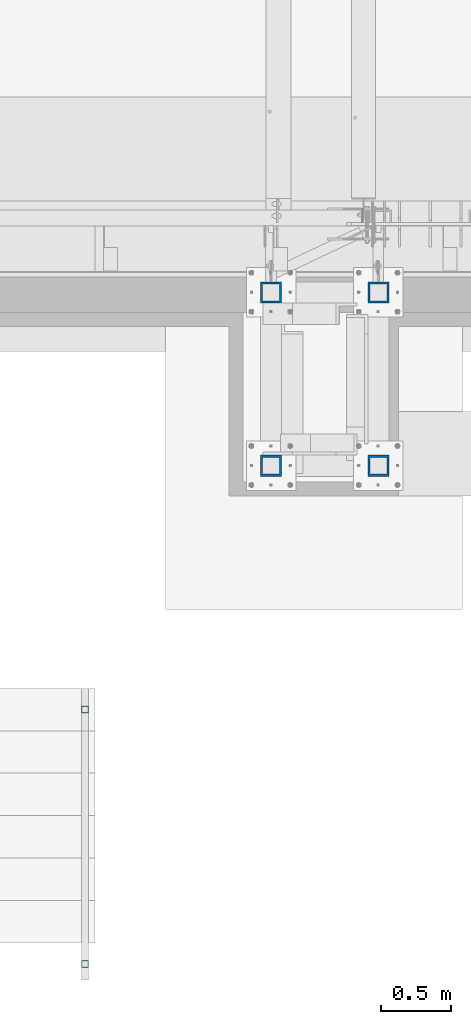
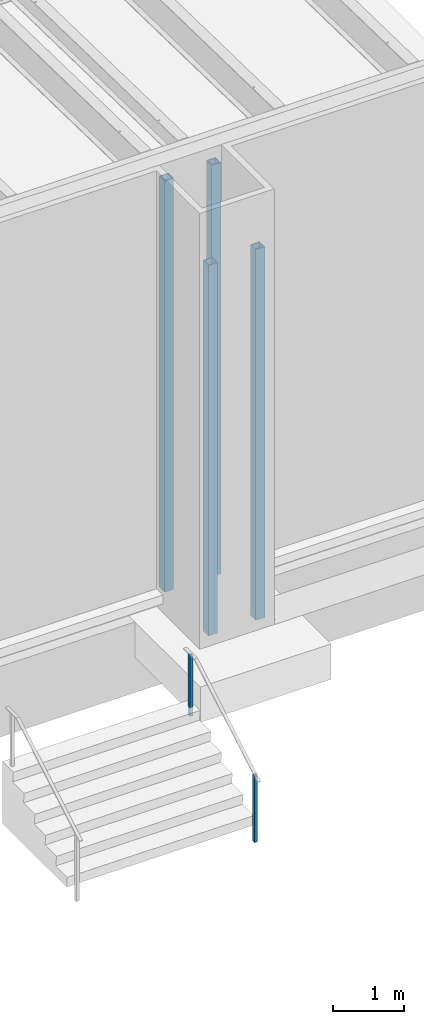
# One storey, part 910 of 1763: 6 columns, 2 elements without a shape of their own.
"""IFC2X3 building model written with IfcOpenShell, lengths in millimetres."""

from ifc_helpers import new_model, si_unit, frame, origin_with_axes, place, context, subcontext, project, spatial, faceted_brep, material, type_object, element, aggregate, save


model = new_model("IFC2X3")

# Units and contexts
model_context = context("Model", 3, precision=1e-05, world=origin_with_axes())
body_context = subcontext(model_context, "Body", "Model", "MODEL_VIEW")
ifc_project = project(units=[si_unit("LENGTHUNIT", "METRE", prefix="MILLI"), si_unit("AREAUNIT", "SQUARE_METRE"), si_unit("VOLUMEUNIT", "CUBIC_METRE"), si_unit("MASSUNIT", "GRAM", prefix="KILO"), si_unit("TIMEUNIT", "SECOND"), si_unit("PLANEANGLEUNIT", "RADIAN"), si_unit("SOLIDANGLEUNIT", "STERADIAN"), si_unit("THERMODYNAMICTEMPERATUREUNIT", "DEGREE_CELSIUS"), si_unit("LUMINOUSINTENSITYUNIT", "LUMEN")], contexts=[model_context])

# Site, building, storey
site_placement = place(None, origin_with_axes())
site = spatial("IfcSite", under=ifc_project, at=site_placement, CompositionType="ELEMENT")
building_placement = place(site_placement, origin_with_axes())
building = spatial("IfcBuilding", under=site, at=building_placement, Name="Undefined", CompositionType="ELEMENT")
storey_placement = place(building_placement, origin_with_axes())
storey = spatial("IfcBuildingStorey", under=building, at=storey_placement, Name="Undefined", CompositionType="ELEMENT", Elevation=0.0)

# Assembly, columns
assembly_1_placement = place(storey_placement, origin_with_axes())
assembly_1 = element("IfcElementAssembly", 1, at=assembly_1_placement, inside=storey, Name="FRAME", AssemblyPlace="NOTDEFINED", PredefinedType="RIGID_FRAME")
ifc_material = material()
column_type_1 = type_object("IfcColumnType", Name="HSS6X6X5/8", PredefinedType="NOTDEFINED")
column_1_placement = place(assembly_1_placement, frame((-29863.4870783858, -14208.1242675181, 5029.2), z_axis=(0.0, 1.0, 0.0), x_axis=(0.0, 0.0, 1.0)))
column_1 = element("IfcColumn", 2, at=column_1_placement, type_object=column_type_1, material=ifc_material, Name="COLUMN", ObjectType="HSS6X6X5/8", context=body_context, shape_type="Brep", body=[
    faceted_brep([(63.4999999999973, 60.3249999999971, -60.3250000000007), (63.4999999999973, -60.3249999999971, -60.3250000000007), (7156.45, -60.3249999999971, -60.3250000000007), (7156.45, 60.3249999999971, -60.3250000000007), (63.4999999999973, -60.3249999999971, 60.3250000000007), (7156.45, -60.3249999999971, 60.3250000000007), (63.4999999999973, 60.3249999999971, 60.3250000000007), (7156.45, 60.3249999999971, 60.3250000000007), (63.4999999999973, 76.1999999999971, -76.2000000000007), (63.4999999999973, 76.1999999999971, 76.2000000000007), (7156.45, 76.1999999999971, 76.2000000000007), (7156.45, 76.1999999999971, -76.2000000000007), (63.4999999999973, -76.1999999999971, 76.2000000000007), (7156.45, -76.1999999999971, 76.2000000000007), (63.4999999999973, -76.1999999999971, -76.2000000000007), (7156.45, -76.1999999999971, -76.2000000000007)], [[[0, 1, 2, 3]], [[1, 4, 5, 2]], [[4, 6, 7, 5]], [[6, 0, 3, 7]], [[8, 9, 10, 11]], [[9, 12, 13, 10]], [[12, 14, 15, 13]], [[14, 8, 11, 15]], [[13, 15, 11, 10], [5, 7, 3, 2]], [[14, 12, 9, 8], [6, 4, 1, 0]]]),
])
column_2_placement = place(assembly_1_placement, frame((-30635.0122736984, -14208.1242675181, 5029.2), z_axis=(0.0, 1.0, 0.0), x_axis=(0.0, 0.0, 1.0)))
column_2 = element("IfcColumn", 3, at=column_2_placement, type_object=column_type_1, material=ifc_material, Name="COLUMN", ObjectType="HSS6X6X5/8", context=body_context, shape_type="Brep", body=[
    faceted_brep([(63.4999999999973, 60.3249999999971, -60.3250000000007), (63.4999999999973, -60.3249999999971, -60.3250000000007), (7156.45, -60.3249999999971, -60.3250000000007), (7156.45, 60.3249999999971, -60.3250000000007), (63.4999999999973, -60.3249999999971, 60.3250000000007), (7156.45, -60.3249999999971, 60.3250000000007), (63.4999999999973, 60.3249999999971, 60.3250000000007), (7156.45, 60.3249999999971, 60.3250000000007), (63.4999999999973, 76.1999999999971, -76.2000000000007), (63.4999999999973, 76.1999999999971, 76.2000000000007), (7156.45, 76.1999999999971, 76.2000000000007), (7156.45, 76.1999999999971, -76.2000000000007), (63.4999999999973, -76.1999999999971, 76.2000000000007), (7156.45, -76.1999999999971, 76.2000000000007), (63.4999999999973, -76.1999999999971, -76.2000000000007), (7156.45, -76.1999999999971, -76.2000000000007)], [[[0, 1, 2, 3]], [[1, 4, 5, 2]], [[4, 6, 7, 5]], [[6, 0, 3, 7]], [[8, 9, 10, 11]], [[9, 12, 13, 10]], [[12, 14, 15, 13]], [[14, 8, 11, 15]], [[13, 15, 11, 10], [5, 7, 3, 2]], [[14, 12, 9, 8], [6, 4, 1, 0]]]),
])
column_3_placement = place(assembly_1_placement, frame((-29863.4870783858, -15452.7242675181, 5029.2), z_axis=(0.0, 1.0, 0.0), x_axis=(0.0, 0.0, 1.0)))
column_3 = element("IfcColumn", 4, at=column_3_placement, type_object=column_type_1, material=ifc_material, Name="COLUMN", ObjectType="HSS6X6X5/8", context=body_context, shape_type="Brep", body=[
    faceted_brep([(63.4999999999973, 60.3249999999971, -60.3250000000007), (63.4999999999973, -60.3249999999971, -60.3250000000007), (6457.95, -60.3249999999971, -60.3250000000007), (6457.95, 60.3249999999971, -60.3250000000007), (63.4999999999973, -60.3249999999971, 60.3250000000007), (6457.95, -60.3249999999971, 60.3250000000007), (63.4999999999973, 60.3249999999971, 60.3250000000007), (6457.95, 60.3249999999971, 60.3250000000007), (63.4999999999973, 76.1999999999971, -76.2000000000007), (63.4999999999973, 76.1999999999971, 76.2000000000007), (6457.95, 76.1999999999971, 76.2000000000007), (6457.95, 76.1999999999971, -76.2000000000007), (63.4999999999973, -76.1999999999971, 76.2000000000007), (6457.95, -76.1999999999971, 76.2000000000007), (63.4999999999973, -76.1999999999971, -76.2000000000007), (6457.95, -76.1999999999971, -76.2000000000007)], [[[0, 1, 2, 3]], [[1, 4, 5, 2]], [[4, 6, 7, 5]], [[6, 0, 3, 7]], [[8, 9, 10, 11]], [[9, 12, 13, 10]], [[12, 14, 15, 13]], [[14, 8, 11, 15]], [[13, 15, 11, 10], [5, 7, 3, 2]], [[14, 12, 9, 8], [6, 4, 1, 0]]]),
])
column_4_placement = place(assembly_1_placement, frame((-30635.0122736984, -15452.7242675181, 5029.2), z_axis=(0.0, 1.0, 0.0), x_axis=(0.0, 0.0, 1.0)))
column_4 = element("IfcColumn", 5, at=column_4_placement, type_object=column_type_1, material=ifc_material, Name="FRAME", ObjectType="HSS6X6X5/8", context=body_context, shape_type="Brep", body=[
    faceted_brep([(63.4999999999973, 60.3249999999971, -60.3250000000007), (63.4999999999973, -60.3249999999971, -60.3250000000007), (6457.95, -60.3249999999971, -60.3250000000007), (6457.95, 60.3249999999971, -60.3250000000007), (63.4999999999973, -60.3249999999971, 60.3250000000007), (6457.95, -60.3249999999971, 60.3250000000007), (63.4999999999973, 60.3249999999971, 60.3250000000007), (6457.95, 60.3249999999971, 60.3250000000007), (63.4999999999973, 76.1999999999971, -76.2000000000007), (63.4999999999973, 76.1999999999971, 76.2000000000007), (6457.95, 76.1999999999971, 76.2000000000007), (6457.95, 76.1999999999971, -76.2000000000007), (63.4999999999973, -76.1999999999971, 76.2000000000007), (6457.95, -76.1999999999971, 76.2000000000007), (63.4999999999973, -76.1999999999971, -76.2000000000007), (6457.95, -76.1999999999971, -76.2000000000007)], [[[0, 1, 2, 3]], [[1, 4, 5, 2]], [[4, 6, 7, 5]], [[6, 0, 3, 7]], [[8, 9, 10, 11]], [[9, 12, 13, 10]], [[12, 14, 15, 13]], [[14, 8, 11, 15]], [[13, 15, 11, 10], [5, 7, 3, 2]], [[14, 12, 9, 8], [6, 4, 1, 0]]]),
])
aggregate(assembly_1, [column_1, column_2, column_3, column_4])

assembly_2_placement = place(storey_placement, origin_with_axes())
assembly_2 = element("IfcElementAssembly", 6, at=assembly_2_placement, inside=storey, Name="HANDRAIL", AssemblyPlace="NOTDEFINED", PredefinedType="RIGID_FRAME")
column_type_2 = type_object("IfcColumnType", Name="2X2X3/16 SQUARE TUBE SS", PredefinedType="NOTDEFINED")
column_5_placement = place(assembly_2_placement, frame((-31971.6872736984, -19034.1249975692, 4114.8), z_axis=(-1.0, 0.0, 0.0), x_axis=(0.0, 0.0, 1.0)))
column_5 = element("IfcColumn", 7, at=column_5_placement, type_object=column_type_2, material=ifc_material, Name="POST TUBE", ObjectType="2X2X3/16 SQUARE TUBE SS", context=body_context, shape_type="Brep", body=[
    faceted_brep([(0.0, 20.6375000000007, -20.6374999999971), (0.0, -20.6375000000007, -20.6374999999971), (1132.63432765349, -20.6375000000007, -20.6374999999971), (1156.71140979222, 20.6375000000007, -20.6374999999971), (0.0, -20.6375000000007, 20.6374999999971), (1132.63432765349, -20.6375000000007, 20.6374999999971), (0.0, 20.6375000000007, 20.6374999999971), (1156.71140979222, 20.6375000000007, 20.6374999999971), (-1.45519152283669e-11, 25.4000000000015, -25.3999999999869), (1.45519152283669e-11, 25.4000000000015, 25.3999999999796), (1159.48953465438, 25.4000000000015, 25.4000000000015), (1159.48953465438, 25.4000000000015, -25.4000000000015), (0.0, -25.4000000000015, 25.3999999999942), (1129.85620279133, -25.4000000000015, 25.4000000000015), (-1.45519152283669e-11, -25.4000000000015, -25.3999999999869), (1129.85620279133, -25.4000000000015, -25.4000000000015)], [[[0, 1, 2, 3]], [[1, 4, 5, 2]], [[4, 6, 7, 5]], [[6, 0, 3, 7]], [[8, 9, 10, 11]], [[9, 12, 13, 10]], [[12, 14, 15, 13]], [[14, 8, 11, 15]], [[13, 15, 11, 10], [5, 7, 3, 2]], [[14, 12, 9, 8], [6, 4, 1, 0]]]),
])
column_6_placement = place(assembly_2_placement, frame((-31971.6872736984, -17205.3250036728, 5181.6), z_axis=(-1.0, 0.0, 0.0), x_axis=(0.0, 0.0, 1.0)))
column_6 = element("IfcColumn", 8, at=column_6_placement, type_object=column_type_2, material=ifc_material, Name="POST TUBE", ObjectType="2X2X3/16 SQUARE TUBE SS", context=body_context, shape_type="Brep", body=[
    faceted_brep([(-1.45519152283669e-11, -25.4000000000015, -25.3999999999869), (-1.45519152283669e-11, 25.4000000000015, -25.3999999999869), (1057.27498047955, 25.4000000000015, -25.4000000000015), (1057.27498047955, -25.4000000000015, -25.4000000000015), (0.0, -25.4000000000015, 25.3999999999942), (1057.27498047955, -25.4000000000015, 25.4000000000015), (1.45519152283669e-11, 25.4000000000015, 25.3999999999796), (1057.27498047955, 25.4000000000015, 25.4000000000015), (0.0, 20.6375000000007, 20.6374999999971), (0.0, -20.6375000000007, 20.6374999999971), (0.0, -20.6375000000007, -20.6374999999971), (0.0, 20.6375000000007, -20.6374999999971), (1057.27498047955, -20.6375000000007, 20.6374999999971), (1057.27498047955, -20.6375000000007, -20.6374999999971), (1057.27498047955, 20.6375000000007, -20.6374999999971), (1057.27498047955, 20.6375000000007, 20.6374999999971)], [[[0, 1, 2, 3]], [[4, 0, 3, 5]], [[6, 4, 5, 7]], [[1, 6, 7, 2]], [[0, 4, 6, 1], [8, 9, 10, 11]], [[10, 9, 12, 13]], [[11, 10, 13, 14]], [[8, 11, 14, 15]], [[9, 8, 15, 12]], [[2, 7, 5, 3], [14, 13, 12, 15]]]),
])
aggregate(assembly_2, [column_5, column_6])

save(model, "model.ifc")
